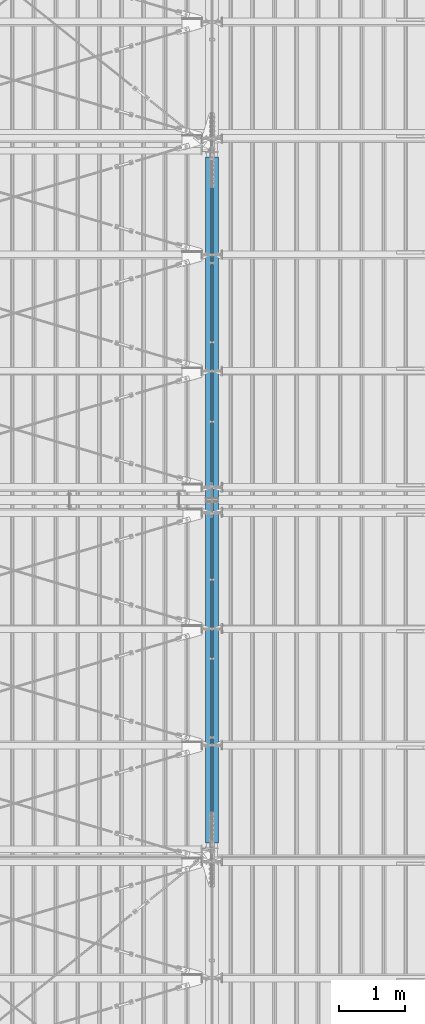
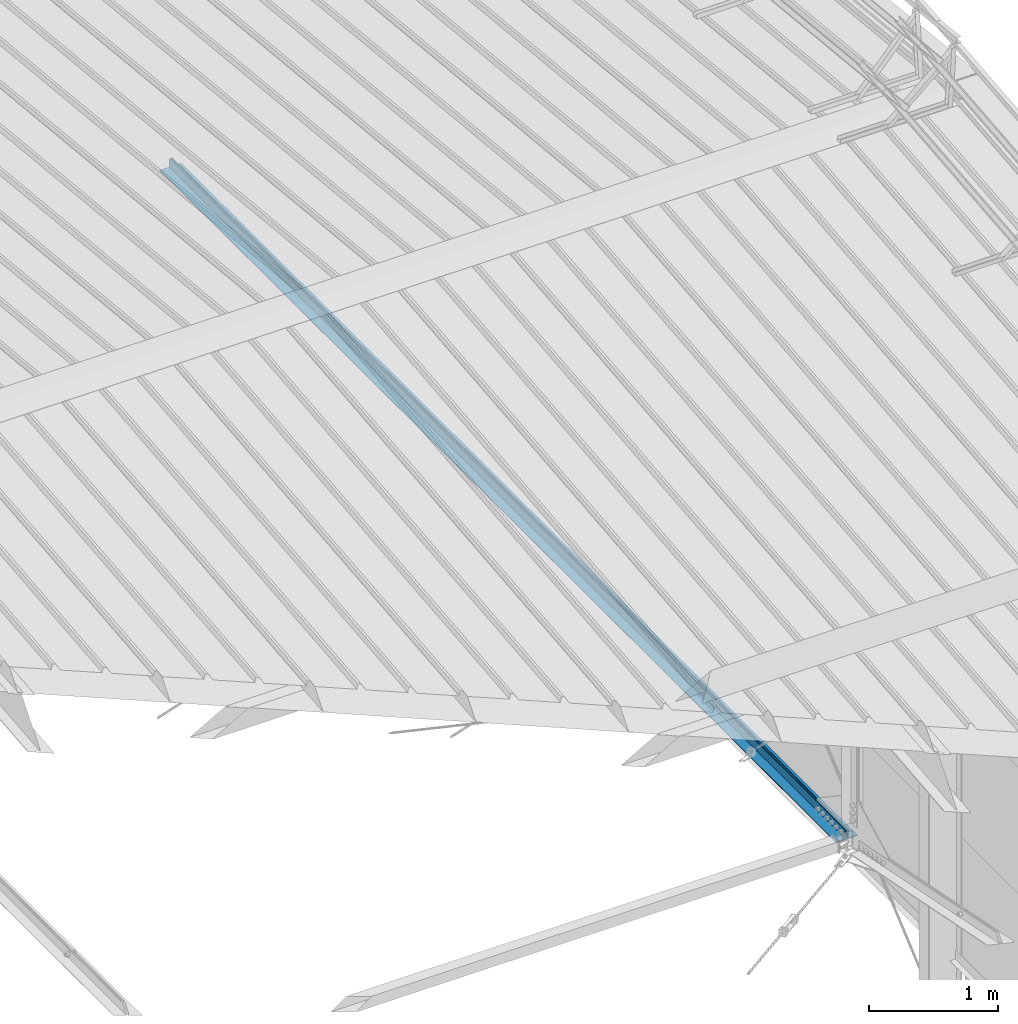
# One storey, part 280 of 709: 2 beams, 2 elements without a shape of their own.
"""IFC4 building model written with IfcOpenShell, lengths in millimetres."""

from ifc_helpers import new_model, si_unit, direction, frame, origin_with_axes, place, context, subcontext, project, spatial, polygons, material, element, aggregate, save


model = new_model("IFC4")

# Units and contexts
model_context = context("Model", 3, precision=0.2, world=origin_with_axes(), true_north=direction((0.0, 1.0)))
body_context = subcontext(model_context, "Body", "Model", "MODEL_VIEW")
ifc_project = project(units=[si_unit("LENGTHUNIT", "METRE", prefix="MILLI"), si_unit("AREAUNIT", "SQUARE_METRE"), si_unit("VOLUMEUNIT", "CUBIC_METRE"), si_unit("MASSUNIT", "GRAM", prefix="KILO"), si_unit("TIMEUNIT", "SECOND"), si_unit("PLANEANGLEUNIT", "RADIAN"), si_unit("SOLIDANGLEUNIT", "STERADIAN"), si_unit("THERMODYNAMICTEMPERATUREUNIT", "DEGREE_CELSIUS"), si_unit("LUMINOUSINTENSITYUNIT", "LUMEN")], contexts=[model_context])

# Site, building, storey
site_placement = place(None, origin_with_axes())
site = spatial("IfcSite", under=ifc_project, at=site_placement, CompositionType="ELEMENT")
building_placement = place(site_placement, origin_with_axes())
building = spatial("IfcBuilding", under=site, at=building_placement, Name="Undefined", CompositionType="ELEMENT")
storey_placement = place(building_placement, origin_with_axes())
storey = spatial("IfcBuildingStorey", under=building, at=storey_placement, Name="Undefined", CompositionType="ELEMENT", Elevation=0.0)

# Assembly, beam
assembly_1_placement = place(storey_placement, frame((45949.0, 5673.0, 6045.00002), z_axis=(0.0, 0.0, 1.0), x_axis=(0.0, 1.0, 0.0)))
assembly_1 = element("IfcElementAssembly", 1, at=assembly_1_placement, inside=storey)
ifc_material = material(Name="C345-5", Category="STEEL")
beam_1_placement = place(assembly_1_placement, origin_with_axes())
beam_1 = element("IfcBeam", 2, at=beam_1_placement, material=ifc_material, ObjectType="433", context=body_context, shape_type="Tessellation", body=[
    polygons([(100.0, -45.0, -45.0), (100.0, 45.0, -45.0), (10554.0, 45.0, -45.0), (10554.0, -45.0, -45.0), (100.0, 45.0, -39.0), (10554.0, 45.0, -39.0), (100.0, -39.0, -39.0), (10554.0, -39.0, -39.0), (100.0, -39.0, 45.0), (10554.0, -39.0, 45.0), (100.0, -45.0, 45.0), (10554.0, -45.0, 45.0)], [[[1, 2, 3, 4]], [[2, 5, 6, 3]], [[5, 7, 8, 6]], [[7, 9, 10, 8]], [[9, 11, 12, 10]], [[11, 1, 4, 12]], [[6, 8, 10, 12, 4, 3]], [[11, 9, 7, 5, 2, 1]]], closed=True),
])
aggregate(assembly_1, [beam_1])

assembly_2_placement = place(storey_placement, frame((46051.0, 16327.0, 6045.00002), z_axis=(0.0, 0.0, 1.0), x_axis=(0.0, -1.0, 0.0)))
assembly_2 = element("IfcElementAssembly", 3, at=assembly_2_placement, inside=storey)
beam_2_placement = place(assembly_2_placement, origin_with_axes())
beam_2 = element("IfcBeam", 4, at=beam_2_placement, material=ifc_material, ObjectType="434", context=body_context, shape_type="Tessellation", body=[
    polygons([(100.0, -45.0, -45.0), (100.0, 45.0, -45.0), (10554.0, 45.0, -45.0), (10554.0, -45.0, -45.0), (100.0, 45.0, -39.0), (10554.0, 45.0, -39.0), (100.0, -39.0, -39.0), (10554.0, -39.0, -39.0), (100.0, -39.0, 45.0), (10554.0, -39.0, 45.0), (100.0, -45.0, 45.0), (10554.0, -45.0, 45.0)], [[[1, 2, 3, 4]], [[2, 5, 6, 3]], [[5, 7, 8, 6]], [[7, 9, 10, 8]], [[9, 11, 12, 10]], [[11, 1, 4, 12]], [[6, 8, 10, 12, 4, 3]], [[11, 9, 7, 5, 2, 1]]], closed=True),
])
aggregate(assembly_2, [beam_2])

save(model, "model.ifc")
